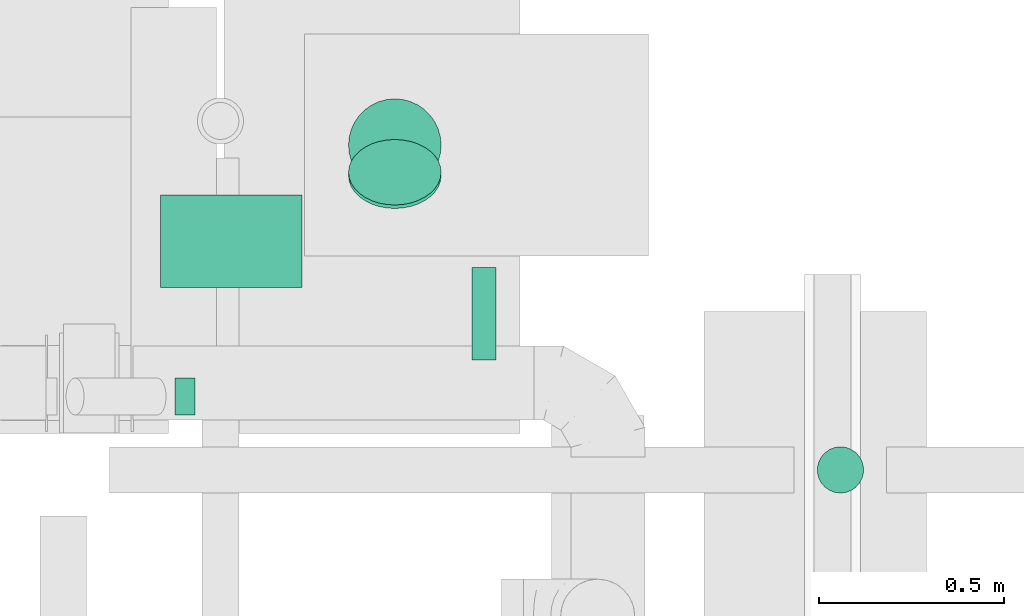
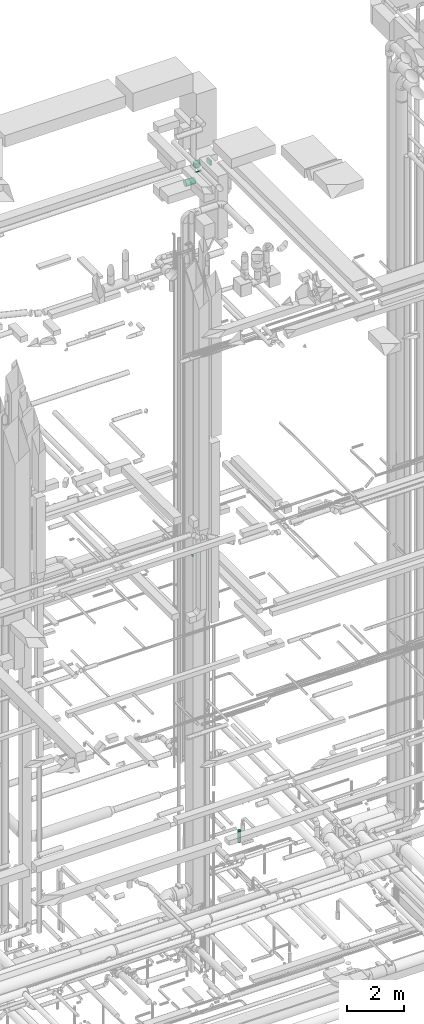
# One storey, part 293 of 337: 6 flow segments.
"""IFC2X3 building model written with IfcOpenShell, lengths in millimetres."""

import ifcopenshell
import ifcopenshell.guid

model = None  # the IFC model being written
_history = None  # IfcOwnerHistory: only IFC2X3 demands one
_inside = {}  # id of a spatial element -> (the spatial element, [elements in it])
_under = {}  # id of a project, library or spatial element -> (it, [spatial elements below it])
_declared = {}  # id of a project -> (the project, [libraries it declares])
_typed = {}  # id of a type object -> (the type object, [elements of that type])
_made_of = {}  # id of a material, layer set ... -> (it, [elements and type objects made of it])


def new_model(schema):
    """Start an empty IFC model of exactly this schema.

    Asked for "IFC4X3", IfcOpenShell would pick the latest addendum, in which some entities
    have other attributes; the version numbers below select the first issue.
    IFC2X3 requires an IfcOwnerHistory on every rooted entity: one is made here for all.
    """
    global model, _history
    if schema == "IFC4X3":
        model = ifcopenshell.file(schema_version=(4, 3, 0, 0))
    else:
        model = ifcopenshell.file(schema=schema)
    _inside.clear()
    _under.clear()
    _declared.clear()
    _typed.clear()
    _made_of.clear()
    _history = None
    if model.schema == "IFC2X3":
        org = make("IfcOrganization", Name="unknown")
        user = make(
            "IfcPersonAndOrganization",
            ThePerson=make("IfcPerson", FamilyName="unknown"),
            TheOrganization=org,
        )
        app = make(
            "IfcApplication",
            ApplicationDeveloper=org,
            Version="unknown",
            ApplicationFullName="unknown",
            ApplicationIdentifier="unknown",
        )
        _history = make(
            "IfcOwnerHistory",
            OwningUser=user,
            OwningApplication=app,
            ChangeAction="ADDED",
            CreationDate=0,
        )
    return model


def make(cls, **values):
    """One entity of the class cls with the attributes given. An attribute that is None is left unset."""
    return model.create_entity(
        cls, **{name: value for name, value in values.items() if value is not None}
    )


def entity(cls, *values):
    """Any entity or typed value of the class cls, its attributes in the order of the schema. None: left unset."""
    e = model.create_entity(cls)
    for i, value in enumerate(values):
        if value is not None:
            e[i] = value
    return e


def rooted(cls, **values):
    """An entity with a GlobalId (a new one), such as an element, a storey or a relation."""
    return make(cls, GlobalId=ifcopenshell.guid.new(), OwnerHistory=_history, **values)


def si_unit(unit_type, name, prefix=None):
    """IfcSIUnit, for example si_unit("LENGTHUNIT", "METRE", prefix="MILLI")."""
    return make("IfcSIUnit", UnitType=unit_type, Prefix=prefix, Name=name)


def converted_unit(unit_type, name, factor, base, dimensions=None, offset=None):
    """IfcConversionBasedUnit, such as the inch: factor (a typed value) times the base unit."""
    return make(
        "IfcConversionBasedUnit"
        if offset is None
        else "IfcConversionBasedUnitWithOffset",
        ConversionOffset=offset,
        Dimensions=None
        if dimensions is None
        else entity("IfcDimensionalExponents", *dimensions),
        UnitType=unit_type,
        Name=name,
        ConversionFactor=make(
            "IfcMeasureWithUnit", ValueComponent=factor, UnitComponent=base
        ),
    )


def derived_unit(unit_type, elements):
    """IfcDerivedUnit: a product of units, each with its exponent."""
    return make(
        "IfcDerivedUnit",
        Elements=[
            make("IfcDerivedUnitElement", Unit=unit, Exponent=power)
            for unit, power in elements
        ],
        UnitType=unit_type,
    )


def assignment(units):
    """IfcUnitAssignment: the units of a project."""
    return None if units is None else make("IfcUnitAssignment", Units=units)


def point(xyz):
    """IfcCartesianPoint."""
    return None if xyz is None else make("IfcCartesianPoint", Coordinates=xyz)


def direction(xyz):
    """IfcDirection."""
    return None if xyz is None else make("IfcDirection", DirectionRatios=xyz)


def frame(location, z_axis=None, x_axis=None):
    """IfcAxis2Placement3D, a coordinate frame: its origin and axes. An axis left out is left unset."""
    return make(
        "IfcAxis2Placement3D",
        Location=point(location),
        Axis=direction(z_axis),
        RefDirection=direction(x_axis),
    )


def frame_2d(location, x_axis=None):
    """IfcAxis2Placement2D, a coordinate frame in the plane: its origin and x axis."""
    return make(
        "IfcAxis2Placement2D", Location=point(location), RefDirection=direction(x_axis)
    )


def origin():
    """The frame at (0, 0, 0) with its axes left unset."""
    return frame((0.0, 0.0, 0.0))


def origin_2d_with_axis():
    """The frame at (0, 0) in the plane with the x axis (1, 0) written out."""
    return frame_2d((0.0, 0.0), x_axis=(1.0, 0.0))


def place(relative_to, where):
    """IfcLocalPlacement: puts the frame where relative to a parent placement (None: the world)."""
    return make(
        "IfcLocalPlacement", PlacementRelTo=relative_to, RelativePlacement=where
    )


def context(
    kind, dimensions, precision=None, world=None, true_north=None, identifier=None
):
    """IfcGeometricRepresentationContext, for example the 3D "Model" context."""
    return make(
        "IfcGeometricRepresentationContext",
        ContextIdentifier=identifier,
        ContextType=kind,
        CoordinateSpaceDimension=dimensions,
        Precision=precision,
        WorldCoordinateSystem=world,
        TrueNorth=true_north,
    )


def subcontext(parent, identifier, kind, view, scale=None):
    """IfcGeometricRepresentationSubContext, for example "Body" below "Model"."""
    return make(
        "IfcGeometricRepresentationSubContext",
        ContextIdentifier=identifier,
        ContextType=kind,
        ParentContext=parent,
        TargetScale=scale,
        TargetView=view,
    )


def project(units=None, contexts=None):
    """IfcProject with its units and contexts."""
    return rooted(
        "IfcProject",
        Name="project",
        RepresentationContexts=contexts,
        UnitsInContext=assignment(units),
    )


def spatial(cls, under=None, at=None, **own):
    """A site, building, storey or space (cls), placed at a placement, below another one or the project."""
    s = rooted(cls, ObjectPlacement=at, **own)
    if under is not None:
        _under.setdefault(under.id(), (under, []))[1].append(s)
    return s


def profile(cls, at=None, kind="AREA", **sizes):
    """A parametric profile (cls). Its sizes go by their IFC names, for example OverallWidth=200.0."""
    return make(cls, ProfileType=kind, Position=at, **sizes)


def rectangle(**sizes):
    """IfcRectangleProfileDef."""
    return profile("IfcRectangleProfileDef", **sizes)


def circle(**sizes):
    """IfcCircleProfileDef."""
    return profile("IfcCircleProfileDef", **sizes)


def extrude(swept, where, along, depth):
    """IfcExtrudedAreaSolid: the profile swept, set in the frame where, extruded along a direction by depth."""
    return make(
        "IfcExtrudedAreaSolid",
        SweptArea=swept,
        Position=where,
        ExtrudedDirection=direction(along),
        Depth=depth,
    )


def shape(context_of_items, identifier, shape_type, items):
    """IfcShapeRepresentation: the items that make up one representation, for example the "Body"."""
    return make(
        "IfcShapeRepresentation",
        ContextOfItems=context_of_items,
        RepresentationIdentifier=identifier,
        RepresentationType=shape_type,
        Items=items,
    )


def made_of(thing, what):
    """Note that an element or type object is made of a material, layer set ...; save() writes the relation."""
    if what is not None:
        _made_of.setdefault(what.id(), (what, []))[1].append(thing)
    return thing


def type_object(cls, material=None, **own):
    """A type object (cls), such as IfcWallType, which elements share."""
    return made_of(rooted(cls, **own), material)


def element(
    cls,
    number,
    at=None,
    inside=None,
    cuts=None,
    type_object=None,
    material=None,
    context=None,
    identifier="Body",
    shape_type=None,
    held_by="IfcProductDefinitionShape",
    body=None,
    shapes=None,
    **own,
):
    """One element of the class cls, such as IfcWall. Its Tag is "e" and its number.

    at: its placement. inside: the storey or other place that contains it. cuts: it is an
    opening in that element (IfcRelVoidsElement). A single representation is given by context,
    identifier, shape_type and body (its items); several are given by shapes. held_by: the class
    of the entity that holds the representations. save() writes the other relations.
    """
    e = rooted(cls, Tag="e%d" % number, ObjectPlacement=at, **own)
    if body is not None:
        shapes = [shape(context, identifier, shape_type, body)]
    if shapes is not None:
        e.Representation = make(held_by, Representations=shapes)
    if inside is not None:
        _inside.setdefault(inside.id(), (inside, []))[1].append(e)
    if cuts is not None:
        rooted(
            "IfcRelVoidsElement", RelatingBuildingElement=cuts, RelatedOpeningElement=e
        )
    if type_object is not None:
        _typed.setdefault(type_object.id(), (type_object, []))[1].append(e)
    return made_of(e, material)


def aggregate(whole, parts):
    """IfcRelAggregates: a whole, such as a stair, and the parts it consists of."""
    return rooted("IfcRelAggregates", RelatingObject=whole, RelatedObjects=parts)


def save(model, path):
    """Write the relations noted so far, then the file.

    IfcRelAggregates (storeys below a building ...), IfcRelContainedInSpatialStructure (elements
    in a storey), IfcRelDefinesByType, IfcRelAssociatesMaterial and IfcRelDeclares: one each for
    every whole, place, type object, material and project.
    """
    for whole, parts in _under.values():
        aggregate(whole, parts)
    for where, things in _inside.values():
        rooted(
            "IfcRelContainedInSpatialStructure",
            RelatedElements=things,
            RelatingStructure=where,
        )
    for kind, things in _typed.values():
        rooted("IfcRelDefinesByType", RelatedObjects=things, RelatingType=kind)
    for what, things in _made_of.values():
        rooted("IfcRelAssociatesMaterial", RelatedObjects=things, RelatingMaterial=what)
    for by, libraries in _declared.values():
        rooted("IfcRelDeclares", RelatingContext=by, RelatedDefinitions=libraries)
    model.write(path)


model = new_model("IFC2X3")

# Units and contexts
model_context = context("Model", 3, precision=0.01, world=origin(), true_north=direction((6.12303176911189e-17, 1.0)))
body_context = subcontext(model_context, "Body", "Model", "MODEL_VIEW")
ifc_project = project(units=[si_unit("LENGTHUNIT", "METRE", prefix="MILLI"), si_unit("AREAUNIT", "SQUARE_METRE"), si_unit("VOLUMEUNIT", "CUBIC_METRE"), converted_unit("PLANEANGLEUNIT", "DEGREE", entity("IfcRatioMeasure", 0.0174532925199433), si_unit("PLANEANGLEUNIT", "RADIAN"), dimensions=[0, 0, 0, 0, 0, 0, 0]), si_unit("MASSUNIT", "GRAM", prefix="KILO"), derived_unit("MASSDENSITYUNIT", [(si_unit("MASSUNIT", "GRAM", prefix="KILO"), 1), (si_unit("LENGTHUNIT", "METRE"), -3)]), derived_unit("MOMENTOFINERTIAUNIT", [(si_unit("LENGTHUNIT", "METRE"), 4)]), si_unit("TIMEUNIT", "SECOND"), si_unit("FREQUENCYUNIT", "HERTZ"), si_unit("THERMODYNAMICTEMPERATUREUNIT", "DEGREE_CELSIUS"), derived_unit("THERMALTRANSMITTANCEUNIT", [(si_unit("MASSUNIT", "GRAM", prefix="KILO"), 1), (si_unit("THERMODYNAMICTEMPERATUREUNIT", "KELVIN"), -1), (si_unit("TIMEUNIT", "SECOND"), -3)]), derived_unit("VOLUMETRICFLOWRATEUNIT", [(si_unit("LENGTHUNIT", "METRE"), 3), (si_unit("TIMEUNIT", "SECOND"), -1)]), derived_unit("MASSFLOWRATEUNIT", [(si_unit("MASSUNIT", "GRAM", prefix="KILO"), 1), (si_unit("TIMEUNIT", "SECOND"), -1)]), derived_unit("ROTATIONALFREQUENCYUNIT", [(si_unit("TIMEUNIT", "SECOND"), -1)]), si_unit("ELECTRICCURRENTUNIT", "AMPERE"), si_unit("ELECTRICVOLTAGEUNIT", "VOLT"), si_unit("POWERUNIT", "WATT"), si_unit("FORCEUNIT", "NEWTON", prefix="KILO"), si_unit("ILLUMINANCEUNIT", "LUX"), si_unit("LUMINOUSFLUXUNIT", "LUMEN"), si_unit("LUMINOUSINTENSITYUNIT", "CANDELA"), derived_unit("USERDEFINED", [(si_unit("MASSUNIT", "GRAM", prefix="KILO"), -1), (si_unit("LENGTHUNIT", "METRE"), -2), (si_unit("TIMEUNIT", "SECOND"), 3), (si_unit("LUMINOUSFLUXUNIT", "LUMEN"), 1)]), derived_unit("LINEARVELOCITYUNIT", [(si_unit("LENGTHUNIT", "METRE"), 1), (si_unit("TIMEUNIT", "SECOND"), -1)]), si_unit("PRESSUREUNIT", "PASCAL"), derived_unit("USERDEFINED", [(si_unit("LENGTHUNIT", "METRE"), -2), (si_unit("MASSUNIT", "GRAM", prefix="KILO"), 1), (si_unit("TIMEUNIT", "SECOND"), -2)]), derived_unit("LINEARFORCEUNIT", [(si_unit("MASSUNIT", "GRAM", prefix="KILO"), 1), (si_unit("LENGTHUNIT", "METRE"), 1), (si_unit("TIMEUNIT", "SECOND"), -2), (si_unit("LENGTHUNIT", "METRE"), -1)]), derived_unit("PLANARFORCEUNIT", [(si_unit("MASSUNIT", "GRAM", prefix="KILO"), 1), (si_unit("LENGTHUNIT", "METRE"), 1), (si_unit("TIMEUNIT", "SECOND"), -2), (si_unit("LENGTHUNIT", "METRE"), -2)])], contexts=[model_context])

# Site, building, storey
site_placement = place(None, origin())
site = spatial("IfcSite", under=ifc_project, at=site_placement, CompositionType="ELEMENT")
building_placement = place(site_placement, origin())
building = spatial("IfcBuilding", under=site, at=building_placement, CompositionType="ELEMENT")
storey_placement = place(building_placement, origin())
storey = spatial("IfcBuildingStorey", under=building, at=storey_placement, CompositionType="ELEMENT", Elevation=0.0)

# Flow segments
duct_segment_type_1 = type_object("IfcDuctSegmentType", PredefinedType="NOTDEFINED")
flow_segment_1_placement = place(storey_placement, frame((64042.65, 19103.12, 27550.0)))
element("IfcFlowSegment", 1, at=flow_segment_1_placement, inside=storey, type_object=duct_segment_type_1, context=body_context, shape_type="SweptSolid", body=[
    extrude(rectangle(XDim=64.9999999999592, YDim=249.999999999999, at=origin_2d_with_axis()), frame((32.5, 125.0, 0.0), z_axis=(0.0, 0.0, 1.0), x_axis=(-1.0, 0.0, 0.0)), (0.0, 0.0, 1.0), 199.999999999998),
])
duct_segment_type_2 = type_object("IfcDuctSegmentType", PredefinedType="NOTDEFINED")
flow_segment_2_placement = place(storey_placement, frame((64974.07, 18742.36, -1475.0)))
element("IfcFlowSegment", 2, at=flow_segment_2_placement, inside=storey, type_object=duct_segment_type_2, context=body_context, shape_type="SweptSolid", body=[
    extrude(circle(Radius=62.5, at=origin_2d_with_axis()), frame((64.1, 64.1, 0.0), z_axis=(0.0, 0.0, 1.0), x_axis=(0.0, -1.0, 0.0)), (0.0, 0.0, 1.0), 500.000000000009),
])
flow_segment_3_placement = place(storey_placement, frame((63241.46, 18952.95, 11200.54)))
element("IfcFlowSegment", 3, at=flow_segment_3_placement, inside=storey, type_object=duct_segment_type_2, context=body_context, shape_type="SweptSolid", body=[
    extrude(circle(Radius=50.0, at=origin_2d_with_axis()), frame((0.0, 51.6, 51.6), z_axis=(1.0, 0.0, 0.0), x_axis=(0.0, -1.0, 0.0)), (0.0, 0.0, 1.0), 54.1382415644108),
])
flow_segment_4_placement = place(storey_placement, frame((63202.38, 19297.39, 26773.4)))
element("IfcFlowSegment", 4, at=flow_segment_4_placement, inside=storey, type_object=duct_segment_type_2, context=body_context, shape_type="SweptSolid", body=[
    extrude(circle(Radius=125.0, at=origin_2d_with_axis()), frame((0.0, 126.6, 126.6), z_axis=(1.0, 0.0, 0.0), x_axis=(0.0, 0.707106781186551, -0.707106781186544)), (0.0, 0.0, 1.0), 382.499999999982),
])
flow_segment_5_placement = place(storey_placement, frame((63708.29, 19510.78, 26986.79)))
element("IfcFlowSegment", 5, at=flow_segment_5_placement, inside=storey, type_object=duct_segment_type_2, context=body_context, shape_type="SweptSolid", body=[
    extrude(circle(Radius=125.0, at=origin_2d_with_axis()), frame((126.6, 89.98, 89.98), z_axis=(0.0, 0.707106781186548, 0.707106781186548), x_axis=(1.0, 0.0, 0.0)), (0.0, 0.0, 1.0), 13.309524416888),
])
flow_segment_6_placement = place(storey_placement, frame((63708.29, 19556.8, 27262.96)))
element("IfcFlowSegment", 6, at=flow_segment_6_placement, inside=storey, type_object=duct_segment_type_2, context=body_context, shape_type="SweptSolid", body=[
    extrude(circle(Radius=125.0, at=origin_2d_with_axis()), frame((126.6, 126.6, 0.0), z_axis=(0.0, 0.0, 1.0), x_axis=(-1.0, 0.0, 0.0)), (0.0, 0.0, 1.0), 167.0353544372),
])

save(model, "model.ifc")
